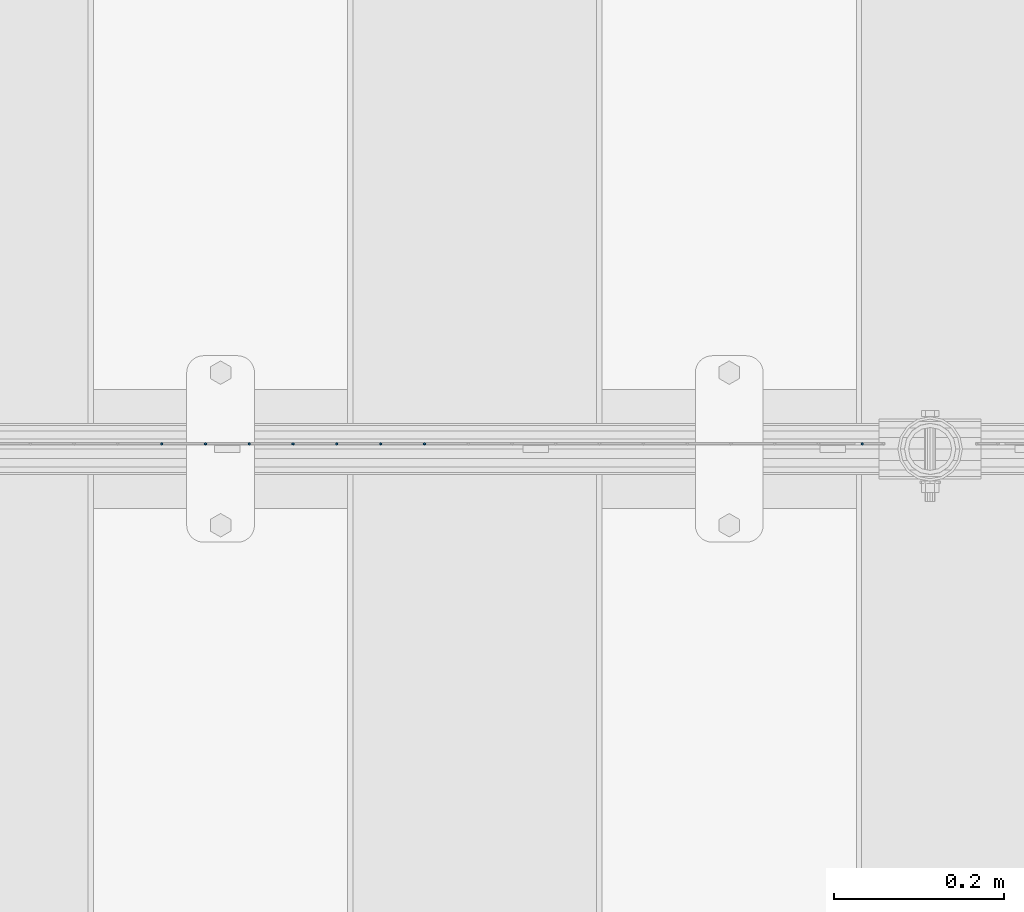
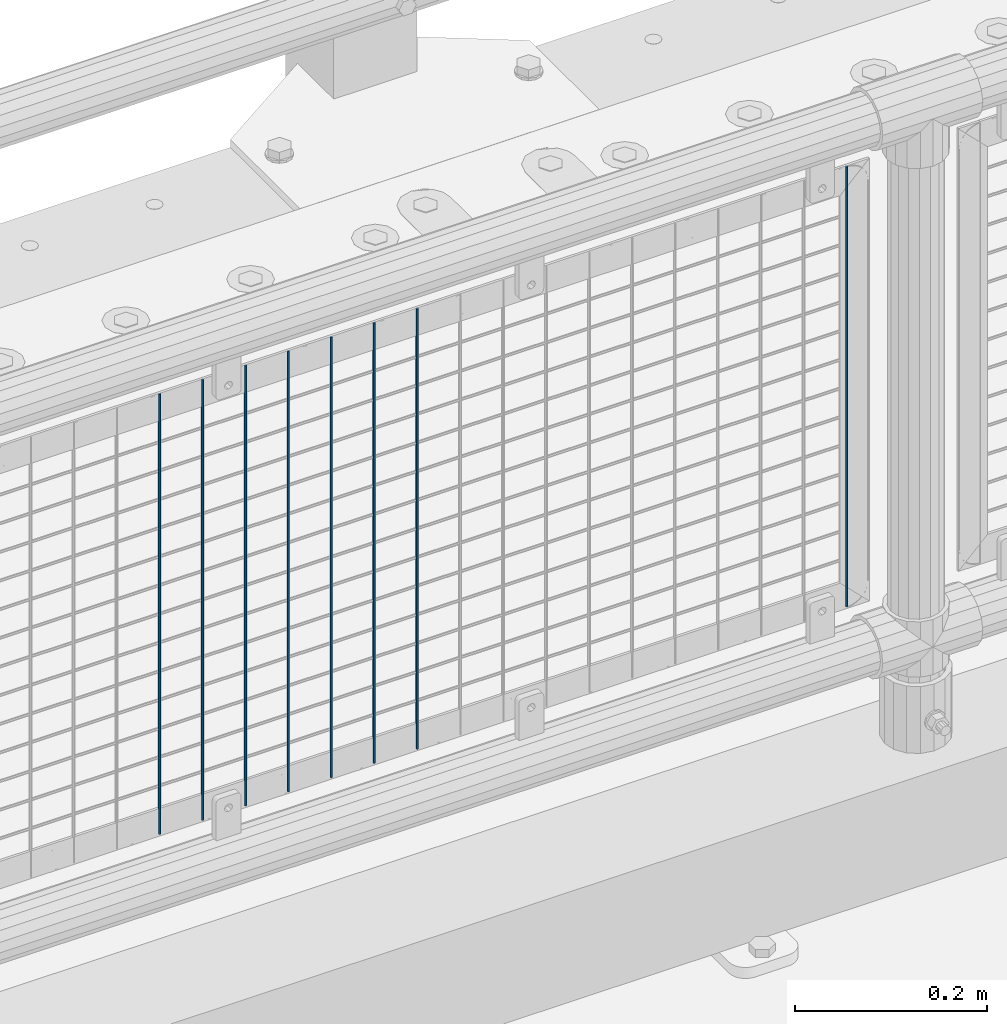
# One storey, part 73 of 240: 8 columns.
"""IFC2X3 building model written with IfcOpenShell, lengths in millimetres."""

import ifcopenshell
import ifcopenshell.guid

model = None  # the IFC model being written
_history = None  # IfcOwnerHistory: only IFC2X3 demands one
_inside = {}  # id of a spatial element -> (the spatial element, [elements in it])
_under = {}  # id of a project, library or spatial element -> (it, [spatial elements below it])
_declared = {}  # id of a project -> (the project, [libraries it declares])
_typed = {}  # id of a type object -> (the type object, [elements of that type])
_made_of = {}  # id of a material, layer set ... -> (it, [elements and type objects made of it])


def new_model(schema):
    """Start an empty IFC model of exactly this schema.

    Asked for "IFC4X3", IfcOpenShell would pick the latest addendum, in which some entities
    have other attributes; the version numbers below select the first issue.
    IFC2X3 requires an IfcOwnerHistory on every rooted entity: one is made here for all.
    """
    global model, _history
    if schema == "IFC4X3":
        model = ifcopenshell.file(schema_version=(4, 3, 0, 0))
    else:
        model = ifcopenshell.file(schema=schema)
    _inside.clear()
    _under.clear()
    _declared.clear()
    _typed.clear()
    _made_of.clear()
    _history = None
    if model.schema == "IFC2X3":
        org = make("IfcOrganization", Name="unknown")
        user = make(
            "IfcPersonAndOrganization",
            ThePerson=make("IfcPerson", FamilyName="unknown"),
            TheOrganization=org,
        )
        app = make(
            "IfcApplication",
            ApplicationDeveloper=org,
            Version="unknown",
            ApplicationFullName="unknown",
            ApplicationIdentifier="unknown",
        )
        _history = make(
            "IfcOwnerHistory",
            OwningUser=user,
            OwningApplication=app,
            ChangeAction="ADDED",
            CreationDate=0,
        )
    return model


def make(cls, **values):
    """One entity of the class cls with the attributes given. An attribute that is None is left unset."""
    return model.create_entity(
        cls, **{name: value for name, value in values.items() if value is not None}
    )


def rooted(cls, **values):
    """An entity with a GlobalId (a new one), such as an element, a storey or a relation."""
    return make(cls, GlobalId=ifcopenshell.guid.new(), OwnerHistory=_history, **values)


def si_unit(unit_type, name, prefix=None):
    """IfcSIUnit, for example si_unit("LENGTHUNIT", "METRE", prefix="MILLI")."""
    return make("IfcSIUnit", UnitType=unit_type, Prefix=prefix, Name=name)


def assignment(units):
    """IfcUnitAssignment: the units of a project."""
    return None if units is None else make("IfcUnitAssignment", Units=units)


def point(xyz):
    """IfcCartesianPoint."""
    return None if xyz is None else make("IfcCartesianPoint", Coordinates=xyz)


def direction(xyz):
    """IfcDirection."""
    return None if xyz is None else make("IfcDirection", DirectionRatios=xyz)


def frame(location, z_axis=None, x_axis=None):
    """IfcAxis2Placement3D, a coordinate frame: its origin and axes. An axis left out is left unset."""
    return make(
        "IfcAxis2Placement3D",
        Location=point(location),
        Axis=direction(z_axis),
        RefDirection=direction(x_axis),
    )


def origin_with_axes():
    """The frame at (0, 0, 0) with the z axis (0, 0, 1) and the x axis (1, 0, 0) written out."""
    return frame((0.0, 0.0, 0.0), z_axis=(0.0, 0.0, 1.0), x_axis=(1.0, 0.0, 0.0))


def place(relative_to, where):
    """IfcLocalPlacement: puts the frame where relative to a parent placement (None: the world)."""
    return make(
        "IfcLocalPlacement", PlacementRelTo=relative_to, RelativePlacement=where
    )


def context(
    kind, dimensions, precision=None, world=None, true_north=None, identifier=None
):
    """IfcGeometricRepresentationContext, for example the 3D "Model" context."""
    return make(
        "IfcGeometricRepresentationContext",
        ContextIdentifier=identifier,
        ContextType=kind,
        CoordinateSpaceDimension=dimensions,
        Precision=precision,
        WorldCoordinateSystem=world,
        TrueNorth=true_north,
    )


def subcontext(parent, identifier, kind, view, scale=None):
    """IfcGeometricRepresentationSubContext, for example "Body" below "Model"."""
    return make(
        "IfcGeometricRepresentationSubContext",
        ContextIdentifier=identifier,
        ContextType=kind,
        ParentContext=parent,
        TargetScale=scale,
        TargetView=view,
    )


def project(units=None, contexts=None):
    """IfcProject with its units and contexts."""
    return rooted(
        "IfcProject",
        Name="project",
        RepresentationContexts=contexts,
        UnitsInContext=assignment(units),
    )


def spatial(cls, under=None, at=None, **own):
    """A site, building, storey or space (cls), placed at a placement, below another one or the project."""
    s = rooted(cls, ObjectPlacement=at, **own)
    if under is not None:
        _under.setdefault(under.id(), (under, []))[1].append(s)
    return s


def faces_of(points, faces, orient=None, outer=None):
    """IfcFace entities. A face is a list of loops; a loop is a list of indices into points, from 0.

    orient and outer hold one flag for each loop. By default every Orientation is true, the
    first loop of a face is its IfcFaceOuterBound and the others are IfcFaceBound.
    """
    made = []
    for i, loops in enumerate(faces):
        bounds = []
        for j, loop in enumerate(loops):
            is_outer = j == 0 if outer is None else outer[i][j]
            bounds.append(
                make(
                    "IfcFaceOuterBound" if is_outer else "IfcFaceBound",
                    Bound=make("IfcPolyLoop", Polygon=[points[k] for k in loop]),
                    Orientation=True if orient is None else orient[i][j],
                )
            )
        made.append(make("IfcFace", Bounds=bounds))
    return made


def faceted_brep(points, faces, orient=None, outer=None, voids=None):
    """IfcFacetedBrep: a solid bounded by flat faces; with voids (closed shells), ...WithVoids."""
    shared = [point(p) for p in points]
    hull = make("IfcClosedShell", CfsFaces=faces_of(shared, faces, orient, outer))
    if voids is None:
        return make("IfcFacetedBrep", Outer=hull)
    return make(
        "IfcFacetedBrepWithVoids",
        Outer=hull,
        Voids=[
            make(cls, CfsFaces=faces_of(shared, fs, o, b)) for cls, fs, o, b in voids
        ],
    )


def shape(context_of_items, identifier, shape_type, items):
    """IfcShapeRepresentation: the items that make up one representation, for example the "Body"."""
    return make(
        "IfcShapeRepresentation",
        ContextOfItems=context_of_items,
        RepresentationIdentifier=identifier,
        RepresentationType=shape_type,
        Items=items,
    )


def material(Name=None, Category=None):
    """IfcMaterial."""
    return make("IfcMaterial", Name=Name, Category=Category)


def made_of(thing, what):
    """Note that an element or type object is made of a material, layer set ...; save() writes the relation."""
    if what is not None:
        _made_of.setdefault(what.id(), (what, []))[1].append(thing)
    return thing


def type_object(cls, material=None, **own):
    """A type object (cls), such as IfcWallType, which elements share."""
    return made_of(rooted(cls, **own), material)


def element(
    cls,
    number,
    at=None,
    inside=None,
    cuts=None,
    type_object=None,
    material=None,
    context=None,
    identifier="Body",
    shape_type=None,
    held_by="IfcProductDefinitionShape",
    body=None,
    shapes=None,
    **own,
):
    """One element of the class cls, such as IfcWall. Its Tag is "e" and its number.

    at: its placement. inside: the storey or other place that contains it. cuts: it is an
    opening in that element (IfcRelVoidsElement). A single representation is given by context,
    identifier, shape_type and body (its items); several are given by shapes. held_by: the class
    of the entity that holds the representations. save() writes the other relations.
    """
    e = rooted(cls, Tag="e%d" % number, ObjectPlacement=at, **own)
    if body is not None:
        shapes = [shape(context, identifier, shape_type, body)]
    if shapes is not None:
        e.Representation = make(held_by, Representations=shapes)
    if inside is not None:
        _inside.setdefault(inside.id(), (inside, []))[1].append(e)
    if cuts is not None:
        rooted(
            "IfcRelVoidsElement", RelatingBuildingElement=cuts, RelatedOpeningElement=e
        )
    if type_object is not None:
        _typed.setdefault(type_object.id(), (type_object, []))[1].append(e)
    return made_of(e, material)


def aggregate(whole, parts):
    """IfcRelAggregates: a whole, such as a stair, and the parts it consists of."""
    return rooted("IfcRelAggregates", RelatingObject=whole, RelatedObjects=parts)


def save(model, path):
    """Write the relations noted so far, then the file.

    IfcRelAggregates (storeys below a building ...), IfcRelContainedInSpatialStructure (elements
    in a storey), IfcRelDefinesByType, IfcRelAssociatesMaterial and IfcRelDeclares: one each for
    every whole, place, type object, material and project.
    """
    for whole, parts in _under.values():
        aggregate(whole, parts)
    for where, things in _inside.values():
        rooted(
            "IfcRelContainedInSpatialStructure",
            RelatedElements=things,
            RelatingStructure=where,
        )
    for kind, things in _typed.values():
        rooted("IfcRelDefinesByType", RelatedObjects=things, RelatingType=kind)
    for what, things in _made_of.values():
        rooted("IfcRelAssociatesMaterial", RelatedObjects=things, RelatingMaterial=what)
    for by, libraries in _declared.values():
        rooted("IfcRelDeclares", RelatingContext=by, RelatedDefinitions=libraries)
    model.write(path)


model = new_model("IFC2X3")

# Units and contexts
model_context = context("Model", 3, precision=1e-05, world=origin_with_axes())
body_context = subcontext(model_context, "Body", "Model", "MODEL_VIEW")
ifc_project = project(units=[si_unit("LENGTHUNIT", "METRE", prefix="MILLI"), si_unit("AREAUNIT", "SQUARE_METRE"), si_unit("VOLUMEUNIT", "CUBIC_METRE"), si_unit("MASSUNIT", "GRAM", prefix="KILO"), si_unit("TIMEUNIT", "SECOND"), si_unit("PLANEANGLEUNIT", "RADIAN"), si_unit("SOLIDANGLEUNIT", "STERADIAN"), si_unit("THERMODYNAMICTEMPERATUREUNIT", "DEGREE_CELSIUS"), si_unit("LUMINOUSINTENSITYUNIT", "LUMEN")], contexts=[model_context])

# Site, building, storey
site_placement = place(None, origin_with_axes())
site = spatial("IfcSite", under=ifc_project, at=site_placement, CompositionType="ELEMENT")
building_placement = place(site_placement, origin_with_axes())
building = spatial("IfcBuilding", under=site, at=building_placement, Name="Standard", CompositionType="ELEMENT")
storey_placement = place(building_placement, origin_with_axes())
storey = spatial("IfcBuildingStorey", under=building, at=storey_placement, Name="Undefined", CompositionType="ELEMENT", Elevation=0.0)

# Columns
ifc_material = material(Name="Misc_Undefined")
column_type = type_object("IfcColumnType", Name="D3", PredefinedType="NOTDEFINED")
for number, where, z_axis, x_axis in (
    (1, (45790.445, 34670.5, 353.02), (-1.0, 0.0, 0.0), (0.0, 0.0, 1.0)),
    (2, (45738.79, 34670.5, 353.02), (-1.0, 0.0, 0.0), (0.0, 0.0, 1.0)),
    (3, (45687.135, 34670.5, 353.02), (-1.0, 0.0, 0.0), (0.0, 0.0, 1.0)),
    (4, (45635.48, 34670.5, 353.02), (-1.0, 0.0, 0.0), (0.0, 0.0, 1.0)),
    (5, (45583.825, 34670.5, 353.02), (-1.0, 0.0, 0.0), (0.0, 0.0, 1.0)),
    (6, (45532.17, 34670.5, 353.02), (-1.0, 0.0, 0.0), (0.0, 0.0, 1.0)),
    (7, (45480.515, 34670.5, 353.02), (-1.0, 0.0, 0.0), (0.0, 0.0, 1.0)),
    (8, (46306.995, 34670.5, 353.02), (-1.0, 0.0, 0.0), (0.0, 0.0, 1.0)),
):
    element("IfcColumn", number, at=place(storey_placement, frame(where, z_axis=z_axis, x_axis=x_axis)), inside=storey, type_object=column_type, material=ifc_material, ObjectType="D3", context=body_context, shape_type="Brep", body=[
        faceted_brep([(-7.27595761418343e-12, -1.49999999999272, 0.0), (-7.27595761418343e-12, -0.749999999992724, -1.29903810567669), (560.0, -0.75, -1.29903810567339), (560.0, -1.5, 0.0), (0.0, 0.750000000007276, -1.29903810567669), (560.0, 0.75, -1.29903810567339), (0.0, 1.50000000000728, 0.0), (560.0, 1.5, 0.0), (0.0, 0.750000000007276, 1.29903810567669), (560.0, 0.75, 1.29903810567339), (-7.27595761418343e-12, -0.749999999992724, 1.29903810567669), (560.0, -0.75, 1.29903810567339)], [[[0, 1, 2, 3]], [[1, 4, 5, 2]], [[4, 6, 7, 5]], [[6, 8, 9, 7]], [[8, 10, 11, 9]], [[10, 0, 3, 11]], [[5, 7, 9, 11, 3, 2]], [[10, 8, 6, 4, 1, 0]]]),
    ])

save(model, "model.ifc")
